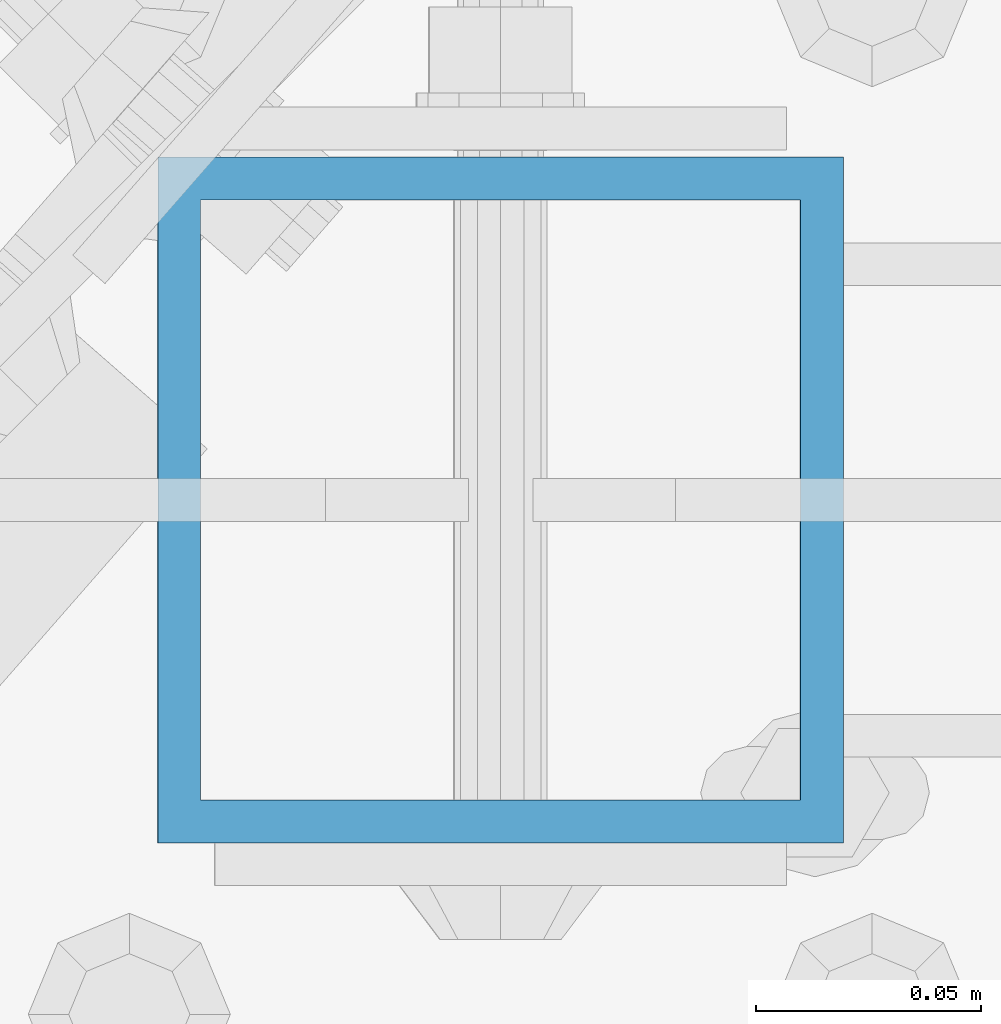
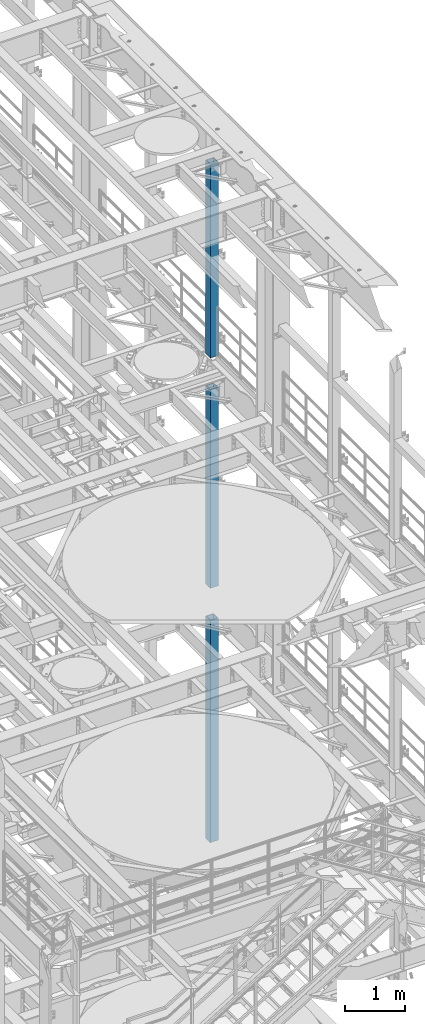
# One storey, part 720 of 1876: 3 columns, 3 elements without a shape of their own.
"""IFC2X3 building model written with IfcOpenShell, lengths in millimetres."""

from ifc_helpers import new_model, si_unit, frame, origin_with_axes, place, context, subcontext, project, spatial, faceted_brep, material, type_object, element, aggregate, save


model = new_model("IFC2X3")

# Units and contexts
model_context = context("Model", 3, precision=1e-05, world=origin_with_axes())
body_context = subcontext(model_context, "Body", "Model", "MODEL_VIEW")
ifc_project = project(units=[si_unit("LENGTHUNIT", "METRE", prefix="MILLI"), si_unit("AREAUNIT", "SQUARE_METRE"), si_unit("VOLUMEUNIT", "CUBIC_METRE"), si_unit("MASSUNIT", "GRAM", prefix="KILO"), si_unit("TIMEUNIT", "SECOND"), si_unit("PLANEANGLEUNIT", "RADIAN"), si_unit("SOLIDANGLEUNIT", "STERADIAN"), si_unit("THERMODYNAMICTEMPERATUREUNIT", "DEGREE_CELSIUS"), si_unit("LUMINOUSINTENSITYUNIT", "LUMEN")], contexts=[model_context])

# Site, building, storey
site_placement = place(None, origin_with_axes())
site = spatial("IfcSite", under=ifc_project, at=site_placement, CompositionType="ELEMENT")
building_placement = place(site_placement, origin_with_axes())
building = spatial("IfcBuilding", under=site, at=building_placement, Name="Undefined", CompositionType="ELEMENT")
storey_placement = place(building_placement, origin_with_axes())
storey = spatial("IfcBuildingStorey", under=building, at=storey_placement, Name="Undefined", CompositionType="ELEMENT", Elevation=0.0)

# Assembly, column
assembly_1_placement = place(storey_placement, origin_with_axes())
assembly_1 = element("IfcElementAssembly", 1, at=assembly_1_placement, inside=storey, Name="BEAM", AssemblyPlace="NOTDEFINED", PredefinedType="RIGID_FRAME")
ifc_material = material()
column_type = type_object("IfcColumnType", Name="HSS6X6X3/8", PredefinedType="NOTDEFINED")
column_1_placement = place(assembly_1_placement, frame((7620.0, 3556.0, 17983.2), z_axis=(-1.0, 0.0, 0.0), x_axis=(0.0, 0.0, 1.0)))
column_1 = element("IfcColumn", 2, at=column_1_placement, type_object=column_type, material=ifc_material, Name="COLUMN", ObjectType="HSS6X6X3/8", context=body_context, shape_type="Brep", body=[
    faceted_brep([(12.7000000000016, 66.6750000000002, -66.6750000000002), (12.7000000000016, -66.6750000000002, -66.6750000000002), (3937.0, -66.6750000000002, -66.675), (3937.0, 66.6750000000002, -66.675), (12.7000000000016, -66.6750000000002, 66.6750000000002), (3937.0, -66.6750000000002, 66.675), (12.7000000000016, 66.6750000000002, 66.6750000000002), (3937.0, 66.6750000000002, 66.675), (12.7000000000016, 76.1999999999998, -76.1999999999998), (12.7000000000016, 76.1999999999998, 76.1999999999998), (3937.0, 76.1999999999998, 76.2), (3937.0, 76.1999999999998, -76.2), (12.7000000000016, -76.1999999999998, 76.1999999999998), (3937.0, -76.1999999999998, 76.2), (12.7000000000016, -76.1999999999998, -76.1999999999998), (3937.0, -76.1999999999998, -76.2)], [[[0, 1, 2, 3]], [[1, 4, 5, 2]], [[4, 6, 7, 5]], [[6, 0, 3, 7]], [[8, 9, 10, 11]], [[9, 12, 13, 10]], [[12, 14, 15, 13]], [[14, 8, 11, 15]], [[13, 15, 11, 10], [5, 7, 3, 2]], [[14, 12, 9, 8], [6, 4, 1, 0]]]),
])
aggregate(assembly_1, [column_1])

assembly_2_placement = place(storey_placement, origin_with_axes())
assembly_2 = element("IfcElementAssembly", 3, at=assembly_2_placement, inside=storey, Name="BEAM", AssemblyPlace="NOTDEFINED", PredefinedType="RIGID_FRAME")
column_2_placement = place(assembly_2_placement, frame((7620.0, 3556.0, 13309.6), z_axis=(-1.0, 0.0, 0.0), x_axis=(0.0, 0.0, 1.0)))
column_2 = element("IfcColumn", 4, at=column_2_placement, type_object=column_type, material=ifc_material, Name="COLUMN", ObjectType="HSS6X6X3/8", context=body_context, shape_type="Brep", body=[
    faceted_brep([(12.7000000000016, 66.6750000000002, -66.6750000000002), (12.7000000000016, -66.6750000000002, -66.6750000000002), (4038.6, -66.6750000000002, -66.675), (4038.6, 66.6750000000002, -66.675), (12.7000000000016, -66.6750000000002, 66.6750000000002), (4038.6, -66.6750000000002, 66.675), (12.7000000000016, 66.6750000000002, 66.6750000000002), (4038.6, 66.6750000000002, 66.675), (12.7000000000016, 76.1999999999998, -76.1999999999998), (12.7000000000016, 76.1999999999998, 76.1999999999998), (4038.6, 76.1999999999998, 76.2), (4038.6, 76.1999999999998, -76.2), (12.7000000000016, -76.1999999999998, 76.1999999999998), (4038.6, -76.1999999999998, 76.2), (12.7000000000016, -76.1999999999998, -76.1999999999998), (4038.6, -76.1999999999998, -76.2)], [[[0, 1, 2, 3]], [[1, 4, 5, 2]], [[4, 6, 7, 5]], [[6, 0, 3, 7]], [[8, 9, 10, 11]], [[9, 12, 13, 10]], [[12, 14, 15, 13]], [[14, 8, 11, 15]], [[13, 15, 11, 10], [5, 7, 3, 2]], [[14, 12, 9, 8], [6, 4, 1, 0]]]),
])
aggregate(assembly_2, [column_2])

assembly_3_placement = place(storey_placement, origin_with_axes())
assembly_3 = element("IfcElementAssembly", 5, at=assembly_3_placement, inside=storey, Name="BEAM", AssemblyPlace="NOTDEFINED", PredefinedType="RIGID_FRAME")
column_3_placement = place(assembly_3_placement, frame((7620.0, 3556.0, 8153.4), z_axis=(-0.999999999563517, 0.0, -2.95459999870218e-05), x_axis=(-2.95459999861759e-05, 0.0, 0.999999999563517)))
column_3 = element("IfcColumn", 6, at=column_3_placement, type_object=column_type, material=ifc_material, Name="COLUMN", ObjectType="HSS6X6X3/8", context=body_context, shape_type="Brep", body=[
    faceted_brep([(12.698030025992, 66.6750000000002, -66.675), (12.698030025992, -66.6750000000002, -66.675), (4521.2007045434, -66.6750000000002, -66.675), (4521.2007045434, 66.6750000000002, -66.675), (12.7019699850925, -66.6750000000002, 66.675), (4521.20070454334, -66.6750000000002, 66.675), (12.7019699850925, 66.6750000000002, 66.675), (4521.20070454334, 66.6750000000002, 66.675), (12.6977486003425, 76.1999999999998, -76.2), (12.7022514107421, 76.1999999999998, 76.2), (4521.20070454334, 76.1999999999998, 76.2), (4521.2007045434, 76.1999999999998, -76.2), (12.7022514107421, -76.1999999999998, 76.2), (4521.20070454334, -76.1999999999998, 76.2), (12.6977486003425, -76.1999999999998, -76.2), (4521.2007045434, -76.1999999999998, -76.2)], [[[0, 1, 2, 3]], [[1, 4, 5, 2]], [[4, 6, 7, 5]], [[6, 0, 3, 7]], [[8, 9, 10, 11]], [[9, 12, 13, 10]], [[12, 14, 15, 13]], [[14, 8, 11, 15]], [[13, 15, 11, 10], [5, 7, 3, 2]], [[14, 12, 9, 8], [6, 4, 1, 0]]]),
])
aggregate(assembly_3, [column_3])

save(model, "model.ifc")
